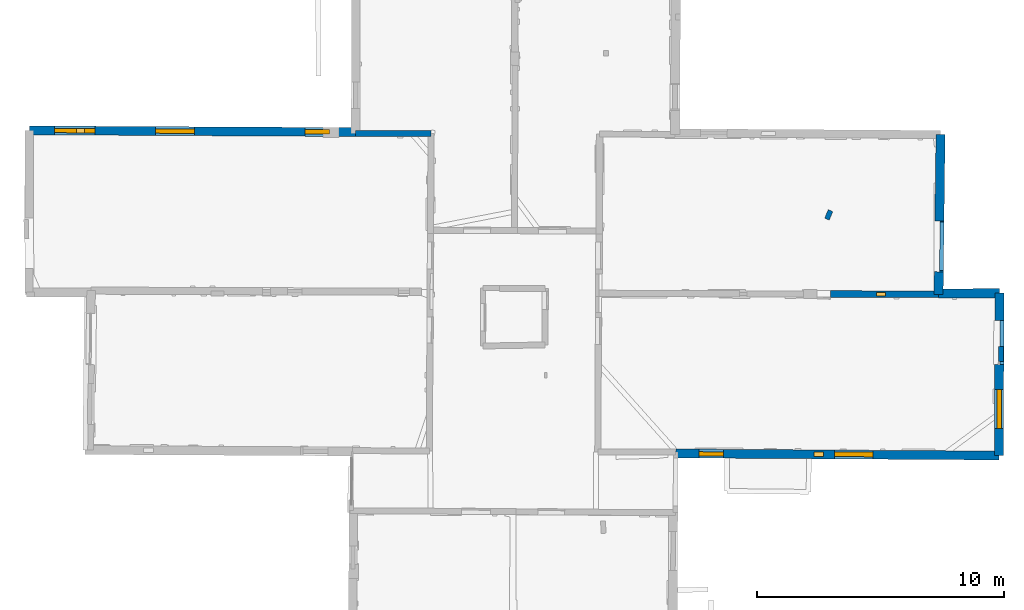
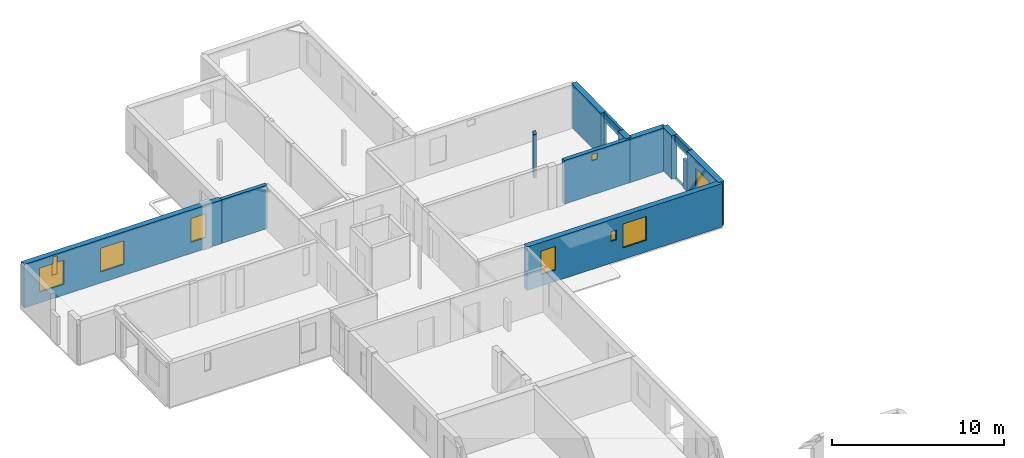
# One storey, part 11 of 17: 13 walls, 9 windows, 11 openings.
"""IFC2X3 building model written with IfcOpenShell, lengths in metres."""

from ifc_helpers import new_model, entity, si_unit, converted_unit, derived_unit, direction, frame, frame_2d, origin, origin_2d_with_axis, place, context, subcontext, project, spatial, polyline, rectangle, outline, extrude, clip, halfspace, source, transform, mapped, material, layer, layer_set, layer_usage, type_object, type_shapes, element, fill, save


model = new_model("IFC2X3")

# Units and contexts
model_context = context("Model", 3, precision=1e-05, world=origin(), true_north=direction((0.0, 1.0)))
body_context = subcontext(model_context, "Body", "Model", "MODEL_VIEW")
ifc_project = project(units=[si_unit("LENGTHUNIT", "METRE"), si_unit("AREAUNIT", "SQUARE_METRE"), si_unit("VOLUMEUNIT", "CUBIC_METRE"), converted_unit("PLANEANGLEUNIT", "DEGREE", entity("IfcRatioMeasure", 0.0174532925199433), si_unit("PLANEANGLEUNIT", "RADIAN"), dimensions=[0, 0, 0, 0, 0, 0, 0]), si_unit("MASSUNIT", "GRAM", prefix="KILO"), derived_unit("MASSDENSITYUNIT", [(si_unit("MASSUNIT", "GRAM", prefix="KILO"), 1), (si_unit("LENGTHUNIT", "METRE"), -3)]), derived_unit("MOMENTOFINERTIAUNIT", [(si_unit("LENGTHUNIT", "METRE"), 4)]), si_unit("TIMEUNIT", "SECOND"), si_unit("FREQUENCYUNIT", "HERTZ"), si_unit("THERMODYNAMICTEMPERATUREUNIT", "DEGREE_CELSIUS"), derived_unit("THERMALTRANSMITTANCEUNIT", [(si_unit("MASSUNIT", "GRAM", prefix="KILO"), 1), (si_unit("THERMODYNAMICTEMPERATUREUNIT", "KELVIN"), -1), (si_unit("TIMEUNIT", "SECOND"), -3)]), derived_unit("VOLUMETRICFLOWRATEUNIT", [(si_unit("LENGTHUNIT", "METRE"), 3), (si_unit("TIMEUNIT", "SECOND"), -1)]), si_unit("ELECTRICCURRENTUNIT", "AMPERE"), si_unit("ELECTRICVOLTAGEUNIT", "VOLT"), si_unit("POWERUNIT", "WATT"), si_unit("FORCEUNIT", "NEWTON", prefix="KILO"), si_unit("ILLUMINANCEUNIT", "LUX"), si_unit("LUMINOUSFLUXUNIT", "LUMEN"), si_unit("LUMINOUSINTENSITYUNIT", "CANDELA"), derived_unit("USERDEFINED", [(si_unit("MASSUNIT", "GRAM", prefix="KILO"), -1), (si_unit("LENGTHUNIT", "METRE"), -2), (si_unit("TIMEUNIT", "SECOND"), 3), (si_unit("LUMINOUSFLUXUNIT", "LUMEN"), 1)]), derived_unit("LINEARVELOCITYUNIT", [(si_unit("LENGTHUNIT", "METRE"), 1), (si_unit("TIMEUNIT", "SECOND"), -1)]), si_unit("PRESSUREUNIT", "PASCAL"), derived_unit("USERDEFINED", [(si_unit("LENGTHUNIT", "METRE"), -2), (si_unit("MASSUNIT", "GRAM", prefix="KILO"), 1), (si_unit("TIMEUNIT", "SECOND"), -2)]), derived_unit("LINEARFORCEUNIT", [(si_unit("MASSUNIT", "GRAM", prefix="KILO"), 1), (si_unit("LENGTHUNIT", "METRE"), 1), (si_unit("TIMEUNIT", "SECOND"), -2), (si_unit("LENGTHUNIT", "METRE"), -1)]), derived_unit("PLANARFORCEUNIT", [(si_unit("MASSUNIT", "GRAM", prefix="KILO"), 1), (si_unit("LENGTHUNIT", "METRE"), 1), (si_unit("TIMEUNIT", "SECOND"), -2), (si_unit("LENGTHUNIT", "METRE"), -2)])], contexts=[model_context])

# Site, building, storey
placement = place(None, origin())
site = spatial("IfcSite", under=ifc_project, at=placement, CompositionType="ELEMENT")
building = spatial("IfcBuilding", under=site, at=placement, CompositionType="ELEMENT")
storey_placement = place(placement, frame((0.0, 0.0, 12.0782108306885)))
storey = spatial("IfcBuildingStorey", under=building, at=storey_placement, Name="Level 5", CompositionType="ELEMENT", Elevation=12.0782108306885)

# Walls
ifc_material_1 = material(Name="Default wall")
ifc_layer_1 = layer(ifc_material_1, 0.25)
ifc_layer_set_1 = layer_set([ifc_layer_1], Name="wall_thickness_0.2500")
ifc_layer_usage_1 = layer_usage(ifc_layer_set_1, "AXIS2", "POSITIVE", -0.125)
wall_type_1 = type_object("IfcWallType", Name="wall_thickness_0.2500", PredefinedType="STANDARD", material=ifc_layer_set_1)
wall_1_placement = place(storey_placement, frame((-0.0626036903379876, 64.0918579876792, 0.0), z_axis=(0.0, 0.0, 1.0), x_axis=(0.999999386160552, -0.00110800655154266, 0.0)))
element("IfcWallStandardCase", 1, at=wall_1_placement, inside=storey, type_object=wall_type_1, material=ifc_layer_usage_1, Name="Wall:244", ObjectType="Wall", context=body_context, shape_type="Clipping", body=[
    clip(clip(extrude(outline(polyline([(3.05724832326912, -0.125), (3.05724832326912, 0.125), (0.0, 0.125), (0.0, -0.125), (3.05724832326912, -0.125)])), origin(), (0.0, 0.0, 1.0), 3.09134044647217), halfspace(frame((24.6966271026858, -6.56192688506097, 9.01350348246577), z_axis=(0.00204167504147299, 0.389449834434152, 0.921045415830423), x_axis=(-0.999974914944031, 0.00704204467615896, -0.000760979274747706)), False)), halfspace(frame((-1.21321761817153, 11.7506083780001, 5.79573318480268), z_axis=(-0.38989953608976, 0.000982418990938069, 0.920856876289642), x_axis=(0.920844887838709, -0.00452669864737099, 0.389902810378011)), False)),
])
ifc_layer_2 = layer(ifc_material_1, 0.2)
ifc_layer_set_2 = layer_set([ifc_layer_2], Name="wall_thickness_0.2000")
ifc_layer_usage_2 = layer_usage(ifc_layer_set_2, "AXIS2", "POSITIVE", -0.1)
wall_type_2 = type_object("IfcWallType", Name="wall_thickness_0.2000", PredefinedType="STANDARD", material=ifc_layer_set_2)
wall_2_placement = place(storey_placement, frame((26.110171815602, 55.4583586410192, 0.0), z_axis=(0.0, 0.0, 1.0), x_axis=(-0.00122193942975736, -0.999999253431736, 0.0)))
element("IfcWallStandardCase", 2, at=wall_2_placement, inside=storey, type_object=wall_type_2, material=ifc_layer_usage_2, Name="Wall:342", ObjectType="Wall", context=body_context, shape_type="SweptSolid", body=[
    extrude(outline(polyline([(0.615002137607875, -0.1), (0.615002137607875, 0.1), (0.0, 0.1), (0.0, -0.1), (0.615002137607875, -0.1)])), origin(), (0.0, 0.0, 1.0), 2.07478904724121),
])
wall_3_placement = place(storey_placement, frame((19.1952592005829, 60.9668345097708, 0.0), z_axis=(0.0, 0.0, 1.0), x_axis=(-0.388608345030103, -0.921403035686862, 0.0)))
element("IfcWallStandardCase", 3, at=wall_3_placement, inside=storey, type_object=wall_type_2, material=ifc_layer_usage_2, Name="Wall:372", ObjectType="Wall", context=body_context, shape_type="Clipping", body=[
    clip(extrude(outline(polyline([(0.374997499298387, -0.1), (0.374997499298387, 0.1), (0.0, 0.1), (0.0, -0.1), (0.374997499298387, -0.1)])), origin(), (0.0, 0.0, 1.0), 3.09134044647217), halfspace(frame((1.08126498692536, 6.35082234862353, 9.01350348246577), z_axis=(-0.35979905604926, -0.149063681840431, 0.921045415830423), x_axis=(0.38108587371368, -0.92453933273086, -0.000760979274747706)), False)),
])

# Wall, opening
ifc_layer_3 = layer(ifc_material_1, 0.159999996423721)
ifc_layer_set_3 = layer_set([ifc_layer_3], Name="wall_thickness_0.1600")
ifc_layer_usage_3 = layer_usage(ifc_layer_set_3, "AXIS2", "POSITIVE", -0.0799999982118607)
wall_type_3 = type_object("IfcWallType", Name="wall_thickness_0.1600", PredefinedType="STANDARD", material=ifc_layer_set_3)
wall_4_placement = place(storey_placement, frame((23.7185251207886, 60.5499973693412, 0.0), z_axis=(0.0, 0.0, 1.0), x_axis=(-0.0122322042791455, -0.999925183790504, 0.0)))
wall_4 = element("IfcWallStandardCase", 4, at=wall_4_placement, inside=storey, type_object=wall_type_3, material=ifc_layer_usage_3, Name="Wall:249", ObjectType="Wall", context=body_context, shape_type="Clipping", body=[
    clip(extrude(outline(polyline([(2.0643367273432, -0.0799999982118607), (2.0643367273432, 0.0799999982118607), (0.0, 0.0799999982118607), (0.0, -0.0799999982118607), (2.0643367273432, -0.0799999982118607)])), origin(), (0.0, 0.0, 1.0), 3.09134044647217), halfspace(frame((3.03608882599384, 0.945421265380548, 9.01350348246577), z_axis=(-0.389448448737515, -0.0022907976136852, 0.921045415830423), x_axis=(0.00408238512473794, -0.999991377483944, -0.000760979274747706)), False)),
])
opening_1_placement = place(wall_4_placement, frame((0.0401488230319259, -0.0799999982118607, 0.00578975677490234)))
element("IfcOpeningElement", 5, at=opening_1_placement, cuts=wall_4, Name="Opening : 1975 x 2460 : 223", ObjectType="Opening", context=body_context, shape_type="SweptSolid", body=[
    extrude(rectangle(XDim=1.975, YDim=2.46, at=frame_2d((1.23, 0.9875), x_axis=(0.0, 1.0))), frame((0.0, 0.0, 0.0), z_axis=(0.0, 1.0, 0.0), x_axis=(0.0, 0.0, 1.0)), (0.0, 0.0, 1.0), 0.159999996423721),
])

wall_5_placement = place(storey_placement, frame((26.1462343966045, 56.510201515018, 0.0), z_axis=(0.0, 0.0, 1.0), x_axis=(-0.00218077403956541, -0.999997622109467, 0.0)))
wall_5 = element("IfcWallStandardCase", 6, at=wall_5_placement, inside=storey, type_object=wall_type_3, material=ifc_layer_usage_3, Name="Wall:288", ObjectType="Wall", context=body_context, shape_type="SweptSolid", body=[
    extrude(outline(polyline([(1.78509945961486, -0.0799999982118607), (1.78509945961486, 0.0799999982118607), (0.0, 0.0799999982118607), (0.0, -0.0799999982118607), (1.78509945961486, -0.0799999982118607)])), origin(), (0.0, 0.0, 1.0), 3.09134044647217),
])
opening_2_placement = place(wall_5_placement, frame((-0.0715028562252419, -0.0799999982118607, 0.00578975677490234)))
element("IfcOpeningElement", 7, at=opening_2_placement, cuts=wall_5, Name="Opening : 1950 x 2475 : 242", ObjectType="Opening", context=body_context, shape_type="SweptSolid", body=[
    extrude(rectangle(XDim=1.95, YDim=2.475, at=frame_2d((1.2375, 0.975), x_axis=(0.0, 1.0))), frame((0.0, 0.0, 0.0), z_axis=(0.0, 1.0, 0.0), x_axis=(0.0, 0.0, 1.0)), (0.0, 0.0, 1.0), 0.159999996423721),
])

# Walls
ifc_layer_4 = layer(ifc_material_1, 0.370000004768372)
ifc_layer_set_4 = layer_set([ifc_layer_4], Name="wall_thickness_0.3700")
ifc_layer_usage_4 = layer_usage(ifc_layer_set_4, "AXIS2", "POSITIVE", -0.185000002384186)
wall_type_4 = type_object("IfcWallType", Name="wall_thickness_0.3700", PredefinedType="STANDARD", material=ifc_layer_set_4)
wall_6_placement = place(storey_placement, frame((23.6563357806795, 64.050648322415, 0.0), z_axis=(0.0, 0.0, 1.0), x_axis=(-0.0122312175258817, -0.999925195861088, 0.0)))
element("IfcWallStandardCase", 8, at=wall_6_placement, inside=storey, type_object=wall_type_4, material=ifc_layer_usage_4, Name="Wall:248", ObjectType="Wall", context=body_context, shape_type="Clipping", body=[
    clip(extrude(outline(polyline([(3.49962854695387, -0.185000002384186), (3.49962854695387, 0.185000002384186), (0.0, 0.185000002384186), (0.0, -0.185000002384186), (3.49962854695387, -0.185000002384186)])), origin(), (0.0, 0.0, 1.0), 3.09134044647217), halfspace(frame((6.53571819750666, 1.05042018066366, 9.01350348246577), z_axis=(-0.389448450997946, -0.0022904132954053, 0.921045415830423), x_axis=(0.00408139830615641, -0.999991381512066, -0.000760979274747706)), False)),
])
wall_7_placement = place(storey_placement, frame((23.5882815824237, 58.4870993593939, 0.0), z_axis=(0.0, 0.0, 1.0), x_axis=(-0.0122306805174023, -0.999925202429702, 0.0)))
element("IfcWallStandardCase", 9, at=wall_7_placement, inside=storey, type_object=wall_type_4, material=ifc_layer_usage_4, Name="Wall:250", ObjectType="Wall", context=body_context, shape_type="Clipping", body=[
    clip(extrude(outline(polyline([(0.917129451105372, -0.185000002384186), (0.917129451105372, 0.185000002384186), (0.0, 0.185000002384186), (0.0, -0.185000002384186), (0.917129451105372, -0.185000002384186)])), origin(), (0.0, 0.0, 1.0), 3.09134044647217), halfspace(frame((0.971753589399238, 1.05041978872232, 9.01350348246577), z_axis=(-0.389448452227953, -0.00229020414263968, 0.921045415830423), x_axis=(0.00408086126213326, -0.999991383703831, -0.000760979274747706)), False)),
])
wall_8_placement = place(storey_placement, frame((23.5775127422341, 57.6068418437848, 0.0), z_axis=(0.0, 0.0, 1.0), x_axis=(0.999987845874494, 0.00493032486658472, 0.0)))
element("IfcWallStandardCase", 10, at=wall_8_placement, inside=storey, type_object=wall_type_4, material=ifc_layer_usage_4, Name="Wall:259", ObjectType="Wall", context=body_context, shape_type="SweptSolid", body=[
    extrude(outline(polyline([(2.46739716129598, -0.185000002384186), (2.46739716129598, 0.185000002384186), (0.0, 0.185000002384186), (0.0, -0.185000002384186), (2.46739716129598, -0.185000002384186)])), origin(), (0.0, 0.0, 1.0), 3.09134044647217),
])
wall_9_placement = place(storey_placement, frame((26.0448803171666, 57.6190018500878, 0.0), z_axis=(0.0, 0.0, 1.0), x_axis=(-0.00318868686622562, -0.999994916125112, 0.0)))
element("IfcWallStandardCase", 11, at=wall_9_placement, inside=storey, type_object=wall_type_4, material=ifc_layer_usage_4, Name="Wall:268", ObjectType="Wall", context=body_context, shape_type="SweptSolid", body=[
    extrude(outline(polyline([(1.10839262833765, -0.185000002384186), (1.10839262833765, 0.185000002384186), (0.0, 0.185000002384186), (0.0, -0.185000002384186), (1.10839262833765, -0.185000002384186)])), origin(), (0.0, 0.0, 1.0), 3.09134044647217),
])

# Wall, opening, window
wall_10_placement = place(storey_placement, frame((26.0356563794026, 54.7255235268717, 0.0), z_axis=(0.0, 0.0, 1.0), x_axis=(-0.00318970060609268, -0.999994912892082, 0.0)))
wall_10 = element("IfcWallStandardCase", 12, at=wall_10_placement, inside=storey, type_object=wall_type_4, material=ifc_layer_usage_4, Name="Wall:269", ObjectType="Wall", context=body_context, shape_type="SweptSolid", body=[
    extrude(outline(polyline([(3.69067734420988, -0.185000002384186), (3.69067734420988, 0.185000002384186), (0.0, 0.185000002384186), (0.0, -0.185000002384186), (3.69067734420988, -0.185000002384186)])), origin(), (0.0, 0.0, 1.0), 3.09134044647217),
])
opening_3_placement = place(wall_10_placement, frame((1.00839726957382, -0.185000002384186, 0.800789833068848)))
opening_3 = element("IfcOpeningElement", 13, at=opening_3_placement, cuts=wall_10, Name="Opening : 1595 x 1680 : 234", ObjectType="Opening", context=body_context, shape_type="SweptSolid", body=[
    extrude(rectangle(XDim=1.595, YDim=1.68, at=frame_2d((0.84, 0.7975), x_axis=(0.0, 1.0))), frame((0.0, 0.0, 0.0), z_axis=(0.0, 1.0, 0.0), x_axis=(0.0, 0.0, 1.0)), (0.0, 0.0, 1.0), 0.370000004768372),
])
ifc_material_2 = material(Name="Window Default")
window_style_1 = type_object("IfcWindowStyle", Name="Window : 1595 x 1680mm", ConstructionType="NOTDEFINED", OperationType="NOTDEFINED", ParameterTakesPrecedence=False, Sizeable=False, material=ifc_material_2)
shared_shape_1 = source(origin(), body_context, "Body", "SweptSolid", [
    extrude(rectangle(XDim=0.189999997615814, YDim=1.595, at=origin_2d_with_axis()), frame((0.7975, 0.189999997615814, 0.0), z_axis=(0.0, 0.0, 1.0), x_axis=(0.0, 1.0, 0.0)), (0.0, 0.0, 1.0), 1.68),
])
type_shapes(window_style_1, [shared_shape_1])
window_1_placement = place(opening_3_placement, origin())
window_1 = element("IfcWindow", 14, at=window_1_placement, inside=storey, type_object=window_style_1, Name="Window : 1595 x 1680mm : 127", ObjectType="Window : 1595 x 1680mm", OverallHeight=1.68, OverallWidth=1.595, context=body_context, shape_type="MappedRepresentation", body=[
    mapped(shared_shape_1, transform((0.0, 0.0, 0.0), scale=1.0)),
])
fill(opening_3, window_1)

# Wall, openings, windows
ifc_layer_5 = layer(ifc_material_1, 0.360000014305115)
ifc_layer_set_5 = layer_set([ifc_layer_5], Name="wall_thickness_0.3600")
ifc_layer_usage_5 = layer_usage(ifc_layer_set_5, "AXIS2", "POSITIVE", -0.180000007152557)
wall_type_5 = type_object("IfcWallType", Name="wall_thickness_0.3600", PredefinedType="STANDARD", material=ifc_layer_set_5)
wall_11_placement = place(storey_placement, frame((-13.2988984173468, 64.2230253550855, 0.0), z_axis=(0.0, 0.0, 1.0), x_axis=(0.999985583412236, -0.00536963385054706, 0.0)))
wall_11 = element("IfcWallStandardCase", 15, at=wall_11_placement, inside=storey, type_object=wall_type_5, material=ifc_layer_usage_5, Name="Wall:235", ObjectType="Wall", context=body_context, shape_type="Clipping", body=[
    clip(extrude(outline(polyline([(13.2365523295194, -0.180000007152557), (13.2365523295194, 0.180000007152557), (0.0, 0.180000007152557), (0.0, -0.180000007152557), (13.2365523295194, -0.180000007152557)])), origin(), (0.0, 0.0, 1.0), 3.09134044647217), halfspace(frame((37.9611756323185, -6.5167105841767, 9.01350348246577), z_axis=(0.000381961518072319, 0.389454998790826, 0.921045415830423), x_axis=(-0.999995845002057, 0.00278044765544859, -0.000760979274747706)), False)),
])
opening_4_placement = place(wall_11_placement, frame((1.91742346703426, -0.180000007152557, 1.60478973388672)))
opening_4 = element("IfcOpeningElement", 16, at=opening_4_placement, cuts=wall_11, Name="Opening : 330 x 1335 : 210", ObjectType="Opening", context=body_context, shape_type="SweptSolid", body=[
    extrude(rectangle(XDim=0.33, YDim=1.335, at=frame_2d((0.6675, 0.165), x_axis=(0.0, 1.0))), frame((0.0, 0.0, 0.0), z_axis=(0.0, 1.0, 0.0), x_axis=(0.0, 0.0, 1.0)), (0.0, 0.0, 1.0), 0.360000014305115),
])
opening_5_placement = place(wall_11_placement, frame((1.02944355440039, -0.180000007152557, 0.765789985656738)))
opening_5 = element("IfcOpeningElement", 17, at=opening_5_placement, cuts=wall_11, Name="Opening : 1635 x 1715 : 211", ObjectType="Opening", context=body_context, shape_type="SweptSolid", body=[
    extrude(rectangle(XDim=1.635, YDim=1.715, at=frame_2d((0.8575, 0.8175), x_axis=(0.0, 1.0))), frame((0.0, 0.0, 0.0), z_axis=(0.0, 1.0, 0.0), x_axis=(0.0, 0.0, 1.0)), (0.0, 0.0, 1.0), 0.360000014305115),
])
opening_6_placement = place(wall_11_placement, frame((5.12444277193559, -0.180000007152557, 0.780789375305176)))
opening_6 = element("IfcOpeningElement", 18, at=opening_6_placement, cuts=wall_11, Name="Opening : 1580 x 1685 : 212", ObjectType="Opening", context=body_context, shape_type="SweptSolid", body=[
    extrude(rectangle(XDim=1.58, YDim=1.685, at=frame_2d((0.8425, 0.79), x_axis=(0.0, 1.0))), frame((0.0, 0.0, 0.0), z_axis=(0.0, 1.0, 0.0), x_axis=(0.0, 0.0, 1.0)), (0.0, 0.0, 1.0), 0.360000014305115),
])
opening_7_placement = place(wall_11_placement, frame((11.1844437684029, -0.180000007152557, 0.785789489746094)))
opening_7 = element("IfcOpeningElement", 19, at=opening_7_placement, cuts=wall_11, Name="Opening : 1000 x 1695 : 213", ObjectType="Opening", context=body_context, shape_type="SweptSolid", body=[
    extrude(rectangle(XDim=1.0, YDim=1.695, at=frame_2d((0.8475, 0.5), x_axis=(0.0, 1.0))), frame((0.0, 0.0, 0.0), z_axis=(0.0, 1.0, 0.0), x_axis=(0.0, 0.0, 1.0)), (0.0, 0.0, 1.0), 0.360000014305115),
])
window_style_2 = type_object("IfcWindowStyle", Name="Window : 330 x 1335mm", ConstructionType="NOTDEFINED", OperationType="NOTDEFINED", ParameterTakesPrecedence=False, Sizeable=False, material=ifc_material_2)
shared_shape_2 = source(origin(), body_context, "Body", "SweptSolid", [
    extrude(rectangle(XDim=0.180000007152557, YDim=0.33, at=origin_2d_with_axis()), frame((0.165, 0.180000007152557, 0.0), z_axis=(0.0, 0.0, 1.0), x_axis=(0.0, 1.0, 0.0)), (0.0, 0.0, 1.0), 1.335),
])
type_shapes(window_style_2, [shared_shape_2])
window_2_placement = place(opening_4_placement, origin())
window_2 = element("IfcWindow", 20, at=window_2_placement, inside=storey, type_object=window_style_2, Name="Window : 330 x 1335mm : 112", ObjectType="Window : 330 x 1335mm", OverallHeight=1.335, OverallWidth=0.33, context=body_context, shape_type="MappedRepresentation", body=[
    mapped(shared_shape_2, transform((0.0, 0.0, 0.0), scale=1.0)),
])
fill(opening_4, window_2)
window_style_3 = type_object("IfcWindowStyle", Name="Window : 1635 x 1715mm", ConstructionType="NOTDEFINED", OperationType="NOTDEFINED", ParameterTakesPrecedence=False, Sizeable=False, material=ifc_material_2)
shared_shape_3 = source(origin(), body_context, "Body", "SweptSolid", [
    extrude(rectangle(XDim=0.180000007152557, YDim=1.635, at=origin_2d_with_axis()), frame((0.8175, 0.180000007152557, 0.0), z_axis=(0.0, 0.0, 1.0), x_axis=(0.0, 1.0, 0.0)), (0.0, 0.0, 1.0), 1.715),
])
type_shapes(window_style_3, [shared_shape_3])
window_3_placement = place(opening_5_placement, origin())
window_3 = element("IfcWindow", 21, at=window_3_placement, inside=storey, type_object=window_style_3, Name="Window : 1635 x 1715mm : 113", ObjectType="Window : 1635 x 1715mm", OverallHeight=1.715, OverallWidth=1.635, context=body_context, shape_type="MappedRepresentation", body=[
    mapped(shared_shape_3, transform((0.0, 0.0, 0.0), scale=1.0)),
])
fill(opening_5, window_3)
window_style_4 = type_object("IfcWindowStyle", Name="Window : 1580 x 1685mm", ConstructionType="NOTDEFINED", OperationType="NOTDEFINED", ParameterTakesPrecedence=False, Sizeable=False, material=ifc_material_2)
shared_shape_4 = source(origin(), body_context, "Body", "SweptSolid", [
    extrude(rectangle(XDim=0.180000007152557, YDim=1.58, at=origin_2d_with_axis()), frame((0.79, 0.180000007152557, 0.0), z_axis=(0.0, 0.0, 1.0), x_axis=(0.0, 1.0, 0.0)), (0.0, 0.0, 1.0), 1.685),
])
type_shapes(window_style_4, [shared_shape_4])
window_4_placement = place(opening_6_placement, origin())
window_4 = element("IfcWindow", 22, at=window_4_placement, inside=storey, type_object=window_style_4, Name="Window : 1580 x 1685mm : 114", ObjectType="Window : 1580 x 1685mm", OverallHeight=1.685, OverallWidth=1.58, context=body_context, shape_type="MappedRepresentation", body=[
    mapped(shared_shape_4, transform((0.0, 0.0, 0.0), scale=1.0)),
])
fill(opening_6, window_4)
window_style_5 = type_object("IfcWindowStyle", Name="Window : 1000 x 1695mm", ConstructionType="NOTDEFINED", OperationType="NOTDEFINED", ParameterTakesPrecedence=False, Sizeable=False, material=ifc_material_2)
shared_shape_5 = source(origin(), body_context, "Body", "SweptSolid", [
    extrude(rectangle(XDim=0.180000007152557, YDim=1.0, at=origin_2d_with_axis()), frame((0.5, 0.180000007152557, 0.0), z_axis=(0.0, 0.0, 1.0), x_axis=(0.0, 1.0, 0.0)), (0.0, 0.0, 1.0), 1.695),
])
type_shapes(window_style_5, [shared_shape_5])
window_5_placement = place(opening_7_placement, origin())
window_5 = element("IfcWindow", 23, at=window_5_placement, inside=storey, type_object=window_style_5, Name="Window : 1000 x 1695mm : 115", ObjectType="Window : 1000 x 1695mm", OverallHeight=1.695, OverallWidth=1.0, context=body_context, shape_type="MappedRepresentation", body=[
    mapped(shared_shape_5, transform((0.0, 0.0, 0.0), scale=1.0)),
])
fill(opening_7, window_5)

wall_12_placement = place(storey_placement, frame((12.9179230155332, 51.120841624306, 0.0), z_axis=(0.0, 0.0, 1.0), x_axis=(0.999978487446901, -0.00655931729738536, 0.0)))
wall_12 = element("IfcWallStandardCase", 24, at=wall_12_placement, inside=storey, type_object=wall_type_5, material=ifc_layer_usage_5, Name="Wall:300", ObjectType="Wall", context=body_context, shape_type="Clipping", body=[
    clip(extrude(outline(polyline([(13.106244702081, -0.180000007152557), (13.106244702081, 0.180000007152557), (0.0, 0.180000007152557), (0.0, -0.180000007152557), (13.106244702081, -0.180000007152557)])), origin(), (0.0, 0.0, 1.0), 3.09134044647217), halfspace(frame((-25.7143989085998, 6.51785777828145, 9.01748660239985), z_axis=(-0.00132251508608455, -0.39112751931217, 0.920335544565435), x_axis=(0.999998445311415, -0.00159069036841743, 0.000760972341273259)), False)),
])
opening_8_placement = place(wall_12_placement, frame((0.948804260776034, -0.180000007152557, 0.800789833068848)))
opening_8 = element("IfcOpeningElement", 25, at=opening_8_placement, cuts=wall_12, Name="Opening : 980 x 1680 : 250", ObjectType="Opening", context=body_context, shape_type="SweptSolid", body=[
    extrude(rectangle(XDim=0.98, YDim=1.68, at=frame_2d((0.84, 0.49), x_axis=(0.0, 1.0))), frame((0.0, 0.0, 0.0), z_axis=(0.0, 1.0, 0.0), x_axis=(0.0, 0.0, 1.0)), (0.0, 0.0, 1.0), 0.360000014305115),
])
opening_9_placement = place(wall_12_placement, frame((5.61647288129938, -0.180000007152557, 1.54778957366943)))
opening_9 = element("IfcOpeningElement", 26, at=opening_9_placement, cuts=wall_12, Name="Opening : 375 x 685 : 251", ObjectType="Opening", context=body_context, shape_type="SweptSolid", body=[
    extrude(rectangle(XDim=0.375, YDim=0.685, at=frame_2d((0.3425, 0.1875), x_axis=(0.0, 1.0))), frame((0.0, 0.0, 0.0), z_axis=(0.0, 1.0, 0.0), x_axis=(0.0, 0.0, 1.0)), (0.0, 0.0, 1.0), 0.360000014305115),
])
opening_10_placement = place(wall_12_placement, frame((6.4338046023773, -0.180000007152557, 0.810790061950684)))
opening_10 = element("IfcOpeningElement", 27, at=opening_10_placement, cuts=wall_12, Name="Opening : 1575 x 1700 : 252", ObjectType="Opening", context=body_context, shape_type="SweptSolid", body=[
    extrude(rectangle(XDim=1.575, YDim=1.7, at=frame_2d((0.85, 0.7875), x_axis=(0.0, 1.0))), frame((0.0, 0.0, 0.0), z_axis=(0.0, 1.0, 0.0), x_axis=(0.0, 0.0, 1.0)), (0.0, 0.0, 1.0), 0.360000014305115),
])
window_style_6 = type_object("IfcWindowStyle", Name="Window : 1575 x 1700mm", ConstructionType="NOTDEFINED", OperationType="NOTDEFINED", ParameterTakesPrecedence=False, Sizeable=False, material=ifc_material_2)
shared_shape_6 = source(origin(), body_context, "Body", "SweptSolid", [
    extrude(rectangle(XDim=0.189999997615814, YDim=1.575, at=origin_2d_with_axis()), frame((0.7875, 0.189999997615814, 0.0), z_axis=(0.0, 0.0, 1.0), x_axis=(0.0, 1.0, 0.0)), (0.0, 0.0, 1.0), 1.7),
])
type_shapes(window_style_6, [shared_shape_6])
window_6_placement = place(opening_10_placement, origin())
window_6 = element("IfcWindow", 28, at=window_6_placement, inside=storey, type_object=window_style_6, Name="Window : 1575 x 1700mm : 135", ObjectType="Window : 1575 x 1700mm", OverallHeight=1.7, OverallWidth=1.575, context=body_context, shape_type="MappedRepresentation", body=[
    mapped(shared_shape_6, transform((0.0, 0.0, 0.0), scale=1.0)),
])
fill(opening_10, window_6)
window_style_7 = type_object("IfcWindowStyle", Name="Window : 980 x 1680mm", ConstructionType="NOTDEFINED", OperationType="NOTDEFINED", ParameterTakesPrecedence=False, Sizeable=False, material=ifc_material_2)
shared_shape_7 = source(origin(), body_context, "Body", "SweptSolid", [
    extrude(rectangle(XDim=0.170000001788139, YDim=0.98, at=origin_2d_with_axis()), frame((0.49, 0.170000001788139, 0.0), z_axis=(0.0, 0.0, 1.0), x_axis=(0.0, 1.0, 0.0)), (0.0, 0.0, 1.0), 1.68),
])
type_shapes(window_style_7, [shared_shape_7])
window_7_placement = place(opening_8_placement, origin())
window_7 = element("IfcWindow", 29, at=window_7_placement, inside=storey, type_object=window_style_7, Name="Window : 980 x 1680mm : 133", ObjectType="Window : 980 x 1680mm", OverallHeight=1.68, OverallWidth=0.98, context=body_context, shape_type="MappedRepresentation", body=[
    mapped(shared_shape_7, transform((0.0, 0.0, 0.0), scale=1.0)),
])
fill(opening_8, window_7)
window_style_8 = type_object("IfcWindowStyle", Name="Window : 375 x 685mm", ConstructionType="NOTDEFINED", OperationType="NOTDEFINED", ParameterTakesPrecedence=False, Sizeable=False, material=ifc_material_2)
shared_shape_8 = source(origin(), body_context, "Body", "SweptSolid", [
    extrude(rectangle(XDim=0.180000007152557, YDim=0.375, at=origin_2d_with_axis()), frame((0.1875, 0.180000007152557, 0.0), z_axis=(0.0, 0.0, 1.0), x_axis=(0.0, 1.0, 0.0)), (0.0, 0.0, 1.0), 0.685),
])
type_shapes(window_style_8, [shared_shape_8])
window_8_placement = place(opening_9_placement, origin())
window_8 = element("IfcWindow", 30, at=window_8_placement, inside=storey, type_object=window_style_8, Name="Window : 375 x 685mm : 134", ObjectType="Window : 375 x 685mm", OverallHeight=0.685, OverallWidth=0.375, context=body_context, shape_type="MappedRepresentation", body=[
    mapped(shared_shape_8, transform((0.0, 0.0, 0.0), scale=1.0)),
])
fill(opening_9, window_8)

# Wall, opening, window
ifc_layer_6 = layer(ifc_material_1, 0.270000010728836)
ifc_layer_set_6 = layer_set([ifc_layer_6], Name="wall_thickness_0.2700")
ifc_layer_usage_6 = layer_usage(ifc_layer_set_6, "AXIS2", "POSITIVE", -0.135000005364418)
wall_type_6 = type_object("IfcWallType", Name="wall_thickness_0.2700", PredefinedType="STANDARD", material=ifc_layer_set_6)
wall_13_placement = place(storey_placement, frame((19.1939550811297, 57.58777676331, 0.0), z_axis=(0.0, 0.0, 1.0), x_axis=(0.999991814606745, -0.0040460745802407, 0.0)))
wall_13 = element("IfcWallStandardCase", 31, at=wall_13_placement, inside=storey, type_object=wall_type_6, material=ifc_layer_usage_6, Name="Wall:261", ObjectType="Wall", context=body_context, shape_type="Clipping", body=[
    clip(extrude(outline(polyline([(4.38314401679556, -0.135000005364418), (4.38314401679556, 0.135000005364418), (0.0, 0.135000005364418), (0.0, -0.135000005364418), (4.38314401679556, -0.135000005364418)])), origin(), (0.0, 0.0, 1.0), 3.09134044647217), halfspace(frame((5.4330827924578, -0.0632235166834197, 9.01350348246577), z_axis=(0.000897433557113359, 0.389454152103651, 0.921045415830423), x_axis=(-0.999991288954465, 0.00410401336887297, -0.000760979274747706)), False)),
])
opening_11_placement = place(wall_13_placement, frame((1.85608296048095, -0.135000005364418, 2.43078994750977)))
opening_11 = element("IfcOpeningElement", 32, at=opening_11_placement, cuts=wall_13, Name="Opening : 370 x 455 : 229", ObjectType="Opening", context=body_context, shape_type="SweptSolid", body=[
    extrude(rectangle(XDim=0.37, YDim=0.455, at=frame_2d((0.2275, 0.185), x_axis=(0.0, 1.0))), frame((0.0, 0.0, 0.0), z_axis=(0.0, 1.0, 0.0), x_axis=(0.0, 0.0, 1.0)), (0.0, 0.0, 1.0), 0.270000010728836),
])
window_style_9 = type_object("IfcWindowStyle", Name="Window : 370 x 455mm", ConstructionType="NOTDEFINED", OperationType="NOTDEFINED", ParameterTakesPrecedence=False, Sizeable=False, material=ifc_material_2)
shared_shape_9 = source(origin(), body_context, "Body", "SweptSolid", [
    extrude(rectangle(XDim=0.135000005364418, YDim=0.37, at=origin_2d_with_axis()), frame((0.185, 0.135000005364418, 0.0), z_axis=(0.0, 0.0, 1.0), x_axis=(0.0, 1.0, 0.0)), (0.0, 0.0, 1.0), 0.455),
])
type_shapes(window_style_9, [shared_shape_9])
window_9_placement = place(opening_11_placement, origin())
window_9 = element("IfcWindow", 33, at=window_9_placement, inside=storey, type_object=window_style_9, Name="Window : 370 x 455mm : 124", ObjectType="Window : 370 x 455mm", OverallHeight=0.455, OverallWidth=0.37, context=body_context, shape_type="MappedRepresentation", body=[
    mapped(shared_shape_9, transform((0.0, 0.0, 0.0), scale=1.0)),
])
fill(opening_11, window_9)

save(model, "model.ifc")
